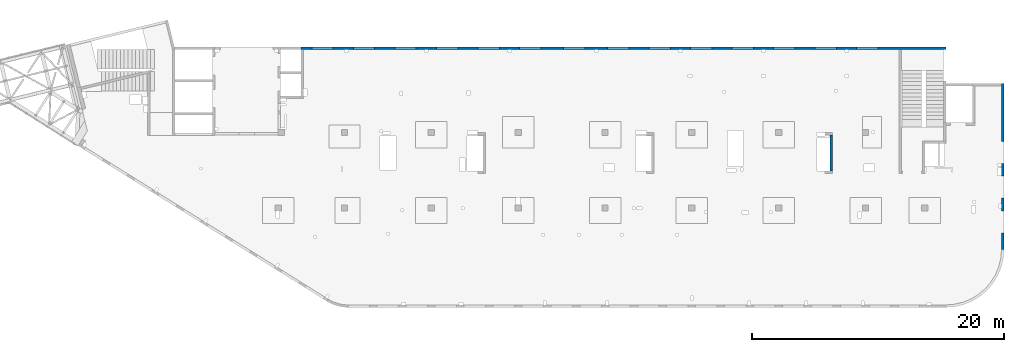
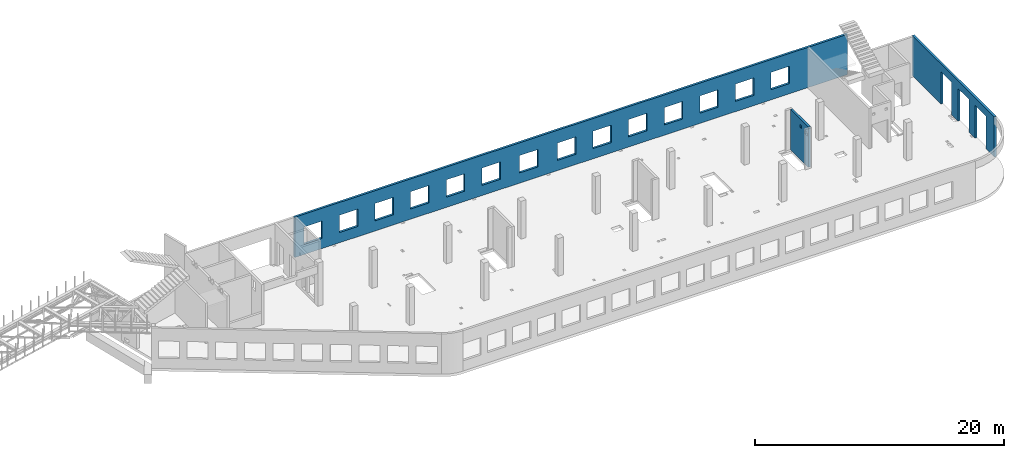
# One storey, part 67 of 67: 3 walls, 19 openings.
"""IFC4 building model written with IfcOpenShell, lengths in millimetres."""

from ifc_helpers import new_model, entity, si_unit, converted_unit, derived_unit, direction, frame, origin, place, context, subcontext, project, spatial, indexed_curve, outline, extrude, polygons, material, type_object, element, save


model = new_model("IFC4")

# Units and contexts
model_context = context("Model", 3, precision=0.01, world=origin(), true_north=direction((6.12303176911189e-17, 1.0)))
plan_context = context("Plan", 3, precision=0.01, world=origin(), true_north=direction((6.12303176911189e-17, 1.0)))
body_context = subcontext(model_context, "Body", "Model", "MODEL_VIEW")
ifc_project = project(units=[si_unit("LENGTHUNIT", "METRE", prefix="MILLI"), si_unit("AREAUNIT", "SQUARE_METRE"), si_unit("VOLUMEUNIT", "CUBIC_METRE"), converted_unit("PLANEANGLEUNIT", "DEGREE", entity("IfcRatioMeasure", 0.0174532925199433), si_unit("PLANEANGLEUNIT", "RADIAN"), dimensions=[0, 0, 0, 0, 0, 0, 0]), si_unit("MASSUNIT", "GRAM", prefix="KILO"), derived_unit("MASSDENSITYUNIT", [(si_unit("MASSUNIT", "GRAM", prefix="KILO"), 1), (si_unit("LENGTHUNIT", "METRE"), -3)]), derived_unit("MOMENTOFINERTIAUNIT", [(si_unit("LENGTHUNIT", "METRE"), 4)]), si_unit("TIMEUNIT", "SECOND"), si_unit("FREQUENCYUNIT", "HERTZ"), si_unit("THERMODYNAMICTEMPERATUREUNIT", "DEGREE_CELSIUS"), derived_unit("THERMALTRANSMITTANCEUNIT", [(si_unit("MASSUNIT", "GRAM", prefix="KILO"), 1), (si_unit("THERMODYNAMICTEMPERATUREUNIT", "KELVIN"), -1), (si_unit("TIMEUNIT", "SECOND"), -3)]), derived_unit("VOLUMETRICFLOWRATEUNIT", [(si_unit("LENGTHUNIT", "METRE"), 3), (si_unit("TIMEUNIT", "SECOND"), -1)]), derived_unit("MASSFLOWRATEUNIT", [(si_unit("MASSUNIT", "GRAM", prefix="KILO"), 1), (si_unit("TIMEUNIT", "SECOND"), -1)]), derived_unit("ROTATIONALFREQUENCYUNIT", [(si_unit("TIMEUNIT", "SECOND"), -1)]), si_unit("ELECTRICCURRENTUNIT", "AMPERE"), si_unit("ELECTRICVOLTAGEUNIT", "VOLT"), si_unit("POWERUNIT", "WATT"), si_unit("FORCEUNIT", "NEWTON", prefix="KILO"), si_unit("ILLUMINANCEUNIT", "LUX"), si_unit("LUMINOUSFLUXUNIT", "LUMEN"), si_unit("LUMINOUSINTENSITYUNIT", "CANDELA"), derived_unit("USERDEFINED", [(si_unit("MASSUNIT", "GRAM", prefix="KILO"), -1), (si_unit("LENGTHUNIT", "METRE"), -2), (si_unit("TIMEUNIT", "SECOND"), 3), (si_unit("LUMINOUSFLUXUNIT", "LUMEN"), 1)]), derived_unit("LINEARVELOCITYUNIT", [(si_unit("LENGTHUNIT", "METRE"), 1), (si_unit("TIMEUNIT", "SECOND"), -1)]), si_unit("PRESSUREUNIT", "PASCAL"), derived_unit("USERDEFINED", [(si_unit("LENGTHUNIT", "METRE"), -2), (si_unit("MASSUNIT", "GRAM", prefix="KILO"), 1), (si_unit("TIMEUNIT", "SECOND"), -2)]), derived_unit("LINEARFORCEUNIT", [(si_unit("MASSUNIT", "GRAM", prefix="KILO"), 1), (si_unit("LENGTHUNIT", "METRE"), 1), (si_unit("TIMEUNIT", "SECOND"), -2), (si_unit("LENGTHUNIT", "METRE"), -1)]), derived_unit("PLANARFORCEUNIT", [(si_unit("MASSUNIT", "GRAM", prefix="KILO"), 1), (si_unit("LENGTHUNIT", "METRE"), 1), (si_unit("TIMEUNIT", "SECOND"), -2), (si_unit("LENGTHUNIT", "METRE"), -2)])], contexts=[model_context, plan_context])

# Site, building, storey
site_placement = place(None, origin())
site = spatial("IfcSite", under=ifc_project, at=site_placement, CompositionType="ELEMENT")
building_placement = place(site_placement, origin())
building = spatial("IfcBuilding", under=site, at=building_placement, CompositionType="ELEMENT")
storey_placement = place(building_placement, frame((0.0, 0.0, 19800.0)))
storey = spatial("IfcBuildingStorey", under=building, at=storey_placement, CompositionType="ELEMENT", Elevation=19800.0)

# Wall, openings
ifc_material = material()
wall_type = type_object("IfcWallType", PredefinedType="STANDARD")
wall_1_placement = place(storey_placement, frame((68970.0002685547, 20399.9998657227, -150.0), z_axis=(0.0, 0.0, 1.0), x_axis=(-1.0, 0.0, 0.0)))
wall_1 = element("IfcWall", 1, at=wall_1_placement, inside=storey, type_object=wall_type, material=ifc_material, PredefinedType="NOTDEFINED", context=body_context, shape_type="Tessellation", body=[
    polygons([(48700.0, -100.000000000319, 2700.0), (50400.0, -100.000000000319, 2700.0), (50400.0, -100.000000000319, 1000.00000000001), (48700.0, -100.000000000319, 1000.00000000001), (45400.0, -100.000000000319, 2700.0), (47100.0, -100.000000000319, 2700.0), (47100.0, -100.000000000319, 1000.00000000001), (45400.0, -100.000000000319, 1000.00000000001), (42100.0, -100.000000000315, 2700.0), (43800.0, -100.000000000319, 2700.0), (43800.0, -100.000000000319, 1000.00000000001), (42100.0, -100.000000000315, 1000.00000000001), (38800.0, -100.000000000315, 2700.0), (40500.0, -100.000000000315, 2700.0), (40500.0, -100.000000000315, 1000.00000000001), (38800.0, -100.000000000315, 1000.00000000001), (35500.0, -100.000000000315, 2700.0), (37200.0, -100.000000000315, 2700.0), (37200.0, -100.000000000315, 1000.00000000001), (35500.0, -100.000000000315, 1000.00000000001), (28700.0, -100.000000000315, 2700.0), (30400.0, -100.000000000315, 2700.0), (30400.0, -100.000000000315, 1000.00000000001), (28700.0, -100.000000000315, 1000.00000000001), (25200.0, -100.000000000319, 2700.0), (26900.0, -100.000000000315, 2700.0), (26900.0, -100.000000000315, 1000.00000000001), (25200.0, -100.000000000319, 1000.00000000001), (21900.0, -100.000000000319, 2700.0), (23600.0, -100.000000000319, 2700.0), (23600.0, -100.000000000319, 1000.00000000001), (21900.0, -100.000000000319, 1000.00000000001), (18600.0, -100.000000000319, 2700.0), (20300.0, -100.000000000319, 2700.0), (20300.0, -100.000000000319, 1000.00000000001), (18600.0, -100.000000000319, 1000.00000000001), (15300.0, -100.000000000319, 2700.0), (17000.0, -100.000000000319, 2700.0), (17000.0, -100.000000000319, 1000.00000000001), (15300.0, -100.000000000319, 1000.00000000001), (12000.0, -100.000000000319, 2700.0), (13700.0, -100.000000000319, 2700.0), (13700.0, -100.000000000319, 1000.00000000001), (12000.0, -100.000000000319, 1000.00000000001), (8700.00000000004, -100.000000000319, 2700.0), (10400.0, -100.000000000319, 2700.0), (10400.0, -100.000000000319, 1000.00000000001), (8700.00000000004, -100.000000000319, 1000.00000000001), (5400.00000000004, -100.000000000319, 2700.0), (7100.00000000004, -100.000000000319, 2700.0), (7100.00000000004, -100.000000000319, 1000.00000000001), (5400.00000000004, -100.000000000319, 1000.00000000001), (32200.0, -100.000000000315, 2700.0), (33900.0, -100.000000000315, 2700.0), (33900.0, -100.000000000315, 1000.00000000001), (32200.0, -100.000000000315, 1000.00000000001), (-1.0404017477463e-11, -99.9999999999989, 0.0), (3539.99999999995, -99.9999999999989, 0.0), (51245.0, -99.9999999999989, 0.0), (51245.0, -99.9999999999989, 3950.0), (3539.99999999995, -99.9999999999989, 3950.0), (-1.0404017477463e-11, -99.9999999999989, 3950.0), (-1.03870313266876e-11, 99.9999999999989, 0.0), (-1.03870313266876e-11, 99.9999999999989, 3950.0), (3539.99999999996, 99.9999999999989, 3950.0), (3739.99999999996, 99.9999999999989, 3950.0), (51045.0, 99.9999999999989, 3950.0), (51245.0, 99.9999999999989, 3950.0), (51245.0, 99.9999999999989, 0.0), (51045.0, 99.9999999999989, 0.0), (3739.99999999996, 99.9999999999989, 0.0), (3539.99999999996, 99.9999999999989, 0.0), (50400.0, 99.9999999999989, 2700.0), (48700.0, 99.9999999999989, 2700.0), (48700.0, 99.9999999999989, 1000.00000000001), (50400.0, 99.9999999999989, 1000.00000000001), (47100.0, 99.9999999999989, 2700.0), (45400.0, 99.9999999999989, 2700.0), (45400.0, 99.9999999999989, 1000.00000000001), (47100.0, 99.9999999999989, 1000.00000000001), (43800.0, 99.9999999999989, 2700.0), (42100.0, 100.000000000003, 2700.0), (42100.0, 100.000000000003, 1000.00000000001), (43800.0, 99.9999999999989, 1000.00000000001), (40500.0, 100.000000000003, 2700.0), (38800.0, 100.000000000003, 2700.0), (38800.0, 100.000000000003, 1000.00000000001), (40500.0, 100.000000000003, 1000.00000000001), (37200.0, 100.000000000003, 2700.0), (35500.0, 100.000000000003, 2700.0), (35500.0, 100.000000000003, 1000.00000000001), (37200.0, 100.000000000003, 1000.00000000001), (30400.0, 100.000000000003, 2700.0), (28700.0, 100.000000000003, 2700.0), (28700.0, 100.000000000003, 1000.00000000001), (30400.0, 100.000000000003, 1000.00000000001), (26900.0, 100.000000000003, 2700.0), (25200.0, 99.9999999999989, 2700.0), (25200.0, 99.9999999999989, 1000.00000000001), (26900.0, 100.000000000003, 1000.00000000001), (23600.0, 99.9999999999989, 2700.0), (21900.0, 99.9999999999989, 2700.0), (21900.0, 99.9999999999989, 1000.00000000001), (23600.0, 99.9999999999989, 1000.00000000001), (20300.0, 99.9999999999989, 2700.0), (18600.0, 99.9999999999989, 2700.0), (18600.0, 99.9999999999989, 1000.00000000001), (20300.0, 99.9999999999989, 1000.00000000001), (17000.0, 99.9999999999989, 2700.0), (15300.0, 99.9999999999989, 2700.0), (15300.0, 99.9999999999989, 1000.00000000001), (17000.0, 99.9999999999989, 1000.00000000001), (13700.0, 99.9999999999989, 2700.0), (12000.0, 99.9999999999989, 2700.0), (12000.0, 99.9999999999989, 1000.00000000001), (13700.0, 99.9999999999989, 1000.00000000001), (10400.0, 99.9999999999989, 2700.0), (8700.00000000004, 99.9999999999989, 2700.0), (8700.00000000004, 99.9999999999989, 1000.00000000001), (10400.0, 99.9999999999989, 1000.00000000001), (7100.00000000004, 99.9999999999989, 2700.0), (5400.00000000004, 99.9999999999989, 2700.0), (5400.00000000004, 99.9999999999989, 1000.00000000001), (7100.00000000004, 99.9999999999989, 1000.00000000001), (33900.0, 100.000000000003, 2700.0), (32200.0, 100.000000000003, 2700.0), (32200.0, 100.000000000003, 1000.00000000001), (33900.0, 100.000000000003, 1000.00000000001)], [[[57, 58, 59, 60, 61, 62], [1, 2, 3, 4], [5, 6, 7, 8], [9, 10, 11, 12], [13, 14, 15, 16], [17, 18, 19, 20], [21, 22, 23, 24], [25, 26, 27, 28], [29, 30, 31, 32], [33, 34, 35, 36], [37, 38, 39, 40], [41, 42, 43, 44], [45, 46, 47, 48], [49, 50, 51, 52], [53, 54, 55, 56]], [[63, 64, 65, 66, 67, 68, 69, 70, 71, 72], [73, 74, 75, 76], [77, 78, 79, 80], [81, 82, 83, 84], [85, 86, 87, 88], [89, 90, 91, 92], [93, 94, 95, 96], [97, 98, 99, 100], [101, 102, 103, 104], [105, 106, 107, 108], [109, 110, 111, 112], [113, 114, 115, 116], [117, 118, 119, 120], [121, 122, 123, 124], [125, 126, 127, 128]], [[59, 58, 57, 63, 72, 71, 70, 69]], [[62, 61, 60, 68, 67, 66, 65, 64]], [[57, 62, 64, 63]], [[2, 1, 74, 73]], [[2, 73, 76, 3]], [[3, 76, 75, 4]], [[74, 1, 4, 75]], [[6, 5, 78, 77]], [[6, 77, 80, 7]], [[7, 80, 79, 8]], [[78, 5, 8, 79]], [[10, 9, 82, 81]], [[10, 81, 84, 11]], [[11, 84, 83, 12]], [[82, 9, 12, 83]], [[14, 13, 86, 85]], [[14, 85, 88, 15]], [[15, 88, 87, 16]], [[86, 13, 16, 87]], [[18, 17, 90, 89]], [[18, 89, 92, 19]], [[19, 92, 91, 20]], [[90, 17, 20, 91]], [[22, 21, 94, 93]], [[22, 93, 96, 23]], [[23, 96, 95, 24]], [[94, 21, 24, 95]], [[26, 25, 98, 97]], [[26, 97, 100, 27]], [[27, 100, 99, 28]], [[98, 25, 28, 99]], [[30, 29, 102, 101]], [[30, 101, 104, 31]], [[31, 104, 103, 32]], [[102, 29, 32, 103]], [[34, 33, 106, 105]], [[34, 105, 108, 35]], [[35, 108, 107, 36]], [[106, 33, 36, 107]], [[38, 37, 110, 109]], [[38, 109, 112, 39]], [[39, 112, 111, 40]], [[110, 37, 40, 111]], [[42, 41, 114, 113]], [[42, 113, 116, 43]], [[43, 116, 115, 44]], [[114, 41, 44, 115]], [[46, 45, 118, 117]], [[46, 117, 120, 47]], [[47, 120, 119, 48]], [[118, 45, 48, 119]], [[50, 49, 122, 121]], [[50, 121, 124, 51]], [[51, 124, 123, 52]], [[122, 49, 52, 123]], [[54, 53, 126, 125]], [[54, 125, 128, 55]], [[55, 128, 127, 56]], [[126, 53, 56, 127]], [[60, 59, 69, 68]]], closed=True),
])
opening_1_placement = place(wall_1_placement, frame((68970.0002685547, 20399.9998657227, 150.0), z_axis=(0.0, 0.0, 1.0), x_axis=(-1.0, 0.0, 0.0)))
element("IfcOpeningElement", 2, at=opening_1_placement, cuts=wall_1, PredefinedType="OPENING", context=body_context, shape_type="SweptSolid", body=[
    extrude(outline(indexed_curve([(-850.000000000002, -849.999999999993), (850.0, -849.999999999993), (850.0, 849.999999999993), (-850.000000000002, 849.999999999993), (-850.000000000002, -849.999999999993)], self_intersect=False)), frame((19420.0002685547, 20499.9998657236, 1700.0), z_axis=(0.0, -1.0, 0.0), x_axis=(-1.0, 0.0, 0.0)), (0.0, 0.0, 1.0), 200.000000000959),
])
opening_2_placement = place(wall_1_placement, frame((68970.0002685547, 20399.9998657227, 150.0), z_axis=(0.0, 0.0, 1.0), x_axis=(-1.0, 0.0, 0.0)))
element("IfcOpeningElement", 3, at=opening_2_placement, cuts=wall_1, PredefinedType="OPENING", context=body_context, shape_type="SweptSolid", body=[
    extrude(outline(indexed_curve([(-850.000000000002, -849.999999999993), (849.999999999997, -849.999999999993), (849.999999999997, 849.999999999993), (-850.000000000002, 849.999999999993), (-850.000000000002, -849.999999999993)], self_intersect=False)), frame((22720.0002685547, 20499.9998657236, 1700.0), z_axis=(0.0, -1.0, 0.0), x_axis=(-1.0, 0.0, 0.0)), (0.0, 0.0, 1.0), 200.000000000959),
])
opening_3_placement = place(wall_1_placement, frame((68970.0002685547, 20399.9998657227, 150.0), z_axis=(0.0, 0.0, 1.0), x_axis=(-1.0, 0.0, 0.0)))
element("IfcOpeningElement", 4, at=opening_3_placement, cuts=wall_1, PredefinedType="OPENING", context=body_context, shape_type="SweptSolid", body=[
    extrude(outline(indexed_curve([(-850.000000000002, -849.999999999993), (849.999999999997, -849.999999999993), (849.999999999997, 849.999999999993), (-850.000000000002, 849.999999999993), (-850.000000000002, -849.999999999993)], self_intersect=False)), frame((26020.0002685547, 20499.9998657236, 1700.0), z_axis=(0.0, -1.0, 0.0), x_axis=(-1.0, 0.0, 0.0)), (0.0, 0.0, 1.0), 200.000000000959),
])
opening_4_placement = place(wall_1_placement, frame((68970.0002685547, 20399.9998657227, 150.0), z_axis=(0.0, 0.0, 1.0), x_axis=(-1.0, 0.0, 0.0)))
element("IfcOpeningElement", 5, at=opening_4_placement, cuts=wall_1, PredefinedType="OPENING", context=body_context, shape_type="SweptSolid", body=[
    extrude(outline(indexed_curve([(-850.000000000002, -849.999999999993), (849.999999999997, -849.999999999993), (849.999999999997, 849.999999999993), (-850.000000000002, 849.999999999993), (-850.000000000002, -849.999999999993)], self_intersect=False)), frame((29320.0002685547, 20499.9998657236, 1700.0), z_axis=(0.0, -1.0, 0.0), x_axis=(-1.0, 0.0, 0.0)), (0.0, 0.0, 1.0), 200.000000000959),
])
opening_5_placement = place(wall_1_placement, frame((68970.0002685547, 20399.9998657227, 150.0), z_axis=(0.0, 0.0, 1.0), x_axis=(-1.0, 0.0, 0.0)))
element("IfcOpeningElement", 6, at=opening_5_placement, cuts=wall_1, PredefinedType="OPENING", context=body_context, shape_type="SweptSolid", body=[
    extrude(outline(indexed_curve([(-849.999999999997, -849.999999999993), (850.000000000002, -849.999999999993), (850.000000000002, 849.999999999993), (-849.999999999997, 849.999999999993), (-849.999999999997, -849.999999999993)], self_intersect=False)), frame((32620.0002685547, 20499.9998657236, 1700.0), z_axis=(0.0, -1.0, 0.0), x_axis=(-1.0, 0.0, 0.0)), (0.0, 0.0, 1.0), 200.000000000959),
])
opening_6_placement = place(wall_1_placement, frame((68970.0002685547, 20399.9998657227, 150.0), z_axis=(0.0, 0.0, 1.0), x_axis=(-1.0, 0.0, 0.0)))
element("IfcOpeningElement", 7, at=opening_6_placement, cuts=wall_1, PredefinedType="OPENING", context=body_context, shape_type="SweptSolid", body=[
    extrude(outline(indexed_curve([(-849.999999999997, -849.999999999993), (850.000000000006, -849.999999999993), (850.000000000006, 849.999999999993), (-849.999999999997, 849.999999999993), (-849.999999999997, -849.999999999993)], self_intersect=False)), frame((39420.0002685547, 20499.9998657236, 1700.0), z_axis=(0.0, -1.0, 0.0), x_axis=(-1.0, 0.0, 0.0)), (0.0, 0.0, 1.0), 200.000000000959),
])
opening_7_placement = place(wall_1_placement, frame((68970.0002685547, 20399.9998657227, 150.0), z_axis=(0.0, 0.0, 1.0), x_axis=(-1.0, 0.0, 0.0)))
element("IfcOpeningElement", 8, at=opening_7_placement, cuts=wall_1, PredefinedType="OPENING", context=body_context, shape_type="SweptSolid", body=[
    extrude(outline(indexed_curve([(-850.000000000006, -849.999999999993), (849.999999999997, -849.999999999993), (849.999999999997, 849.999999999993), (-850.000000000006, 849.999999999993), (-850.000000000006, -849.999999999993)], self_intersect=False)), frame((42920.0002685547, 20499.9998657236, 1700.0), z_axis=(0.0, -1.0, 0.0), x_axis=(-1.0, 0.0, 0.0)), (0.0, 0.0, 1.0), 200.000000000959),
])
opening_8_placement = place(wall_1_placement, frame((68970.0002685547, 20399.9998657227, 150.0), z_axis=(0.0, 0.0, 1.0), x_axis=(-1.0, 0.0, 0.0)))
element("IfcOpeningElement", 9, at=opening_8_placement, cuts=wall_1, PredefinedType="OPENING", context=body_context, shape_type="SweptSolid", body=[
    extrude(outline(indexed_curve([(-849.999999999997, -849.999999999993), (850.000000000006, -849.999999999993), (850.000000000006, 849.999999999993), (-849.999999999997, 849.999999999993), (-849.999999999997, -849.999999999993)], self_intersect=False)), frame((46220.0002685547, 20499.9998657236, 1700.0), z_axis=(0.0, -1.0, 0.0), x_axis=(-1.0, 0.0, 0.0)), (0.0, 0.0, 1.0), 200.000000000959),
])
opening_9_placement = place(wall_1_placement, frame((68970.0002685547, 20399.9998657227, 150.0), z_axis=(0.0, 0.0, 1.0), x_axis=(-1.0, 0.0, 0.0)))
element("IfcOpeningElement", 10, at=opening_9_placement, cuts=wall_1, PredefinedType="OPENING", context=body_context, shape_type="SweptSolid", body=[
    extrude(outline(indexed_curve([(-849.999999999997, -849.999999999993), (850.000000000006, -849.999999999993), (850.000000000006, 849.999999999993), (-849.999999999997, 849.999999999993), (-849.999999999997, -849.999999999993)], self_intersect=False)), frame((49520.0002685547, 20499.9998657236, 1700.0), z_axis=(0.0, -1.0, 0.0), x_axis=(-1.0, 0.0, 0.0)), (0.0, 0.0, 1.0), 200.000000000959),
])
opening_10_placement = place(wall_1_placement, frame((68970.0002685547, 20399.9998657227, 150.0), z_axis=(0.0, 0.0, 1.0), x_axis=(-1.0, 0.0, 0.0)))
element("IfcOpeningElement", 11, at=opening_10_placement, cuts=wall_1, PredefinedType="OPENING", context=body_context, shape_type="SweptSolid", body=[
    extrude(outline(indexed_curve([(-849.999999999997, -849.999999999993), (850.000000000006, -849.999999999993), (850.000000000006, 849.999999999993), (-849.999999999997, 849.999999999993), (-849.999999999997, -849.999999999993)], self_intersect=False)), frame((52820.0002685547, 20499.9998657236, 1700.0), z_axis=(0.0, -1.0, 0.0), x_axis=(-1.0, 0.0, 0.0)), (0.0, 0.0, 1.0), 200.000000000959),
])
opening_11_placement = place(wall_1_placement, frame((68970.0002685547, 20399.9998657227, 150.0), z_axis=(0.0, 0.0, 1.0), x_axis=(-1.0, 0.0, 0.0)))
element("IfcOpeningElement", 12, at=opening_11_placement, cuts=wall_1, PredefinedType="OPENING", context=body_context, shape_type="SweptSolid", body=[
    extrude(outline(indexed_curve([(-849.999999999997, -849.999999999993), (850.000000000006, -849.999999999993), (850.000000000006, 849.999999999993), (-849.999999999997, 849.999999999993), (-849.999999999997, -849.999999999993)], self_intersect=False)), frame((56120.0002685547, 20499.9998657236, 1700.0), z_axis=(0.0, -1.0, 0.0), x_axis=(-1.0, 0.0, 0.0)), (0.0, 0.0, 1.0), 200.000000000959),
])
opening_12_placement = place(wall_1_placement, frame((68970.0002685547, 20399.9998657227, 150.0), z_axis=(0.0, 0.0, 1.0), x_axis=(-1.0, 0.0, 0.0)))
element("IfcOpeningElement", 13, at=opening_12_placement, cuts=wall_1, PredefinedType="OPENING", context=body_context, shape_type="SweptSolid", body=[
    extrude(outline(indexed_curve([(-849.999999999997, -849.999999999993), (850.000000000006, -849.999999999993), (850.000000000006, 849.999999999993), (-849.999999999997, 849.999999999993), (-849.999999999997, -849.999999999993)], self_intersect=False)), frame((59420.0002685547, 20499.9998657236, 1700.0), z_axis=(0.0, -1.0, 0.0), x_axis=(-1.0, 0.0, 0.0)), (0.0, 0.0, 1.0), 200.000000000959),
])
opening_13_placement = place(wall_1_placement, frame((68970.0002685547, 20399.9998657227, 150.0), z_axis=(0.0, 0.0, 1.0), x_axis=(-1.0, 0.0, 0.0)))
element("IfcOpeningElement", 14, at=opening_13_placement, cuts=wall_1, PredefinedType="OPENING", context=body_context, shape_type="SweptSolid", body=[
    extrude(outline(indexed_curve([(-849.999999999997, -849.999999999993), (850.000000000006, -849.999999999993), (850.000000000006, 849.999999999993), (-849.999999999997, 849.999999999993), (-849.999999999997, -849.999999999993)], self_intersect=False)), frame((62720.0002685547, 20499.9998657236, 1700.0), z_axis=(0.0, -1.0, 0.0), x_axis=(-1.0, 0.0, 0.0)), (0.0, 0.0, 1.0), 200.000000000959),
])
opening_14_placement = place(wall_1_placement, frame((68970.0002685547, 20399.9998657227, 150.0), z_axis=(0.0, 0.0, 1.0), x_axis=(-1.0, 0.0, 0.0)))
element("IfcOpeningElement", 15, at=opening_14_placement, cuts=wall_1, PredefinedType="OPENING", context=body_context, shape_type="SweptSolid", body=[
    extrude(outline(indexed_curve([(-849.999999999997, -849.999999999993), (850.000000000002, -849.999999999993), (850.000000000002, 849.999999999993), (-849.999999999997, 849.999999999993), (-849.999999999997, -849.999999999993)], self_intersect=False)), frame((35920.0002685547, 20499.9998657236, 1700.0), z_axis=(0.0, -1.0, 0.0), x_axis=(-1.0, 0.0, 0.0)), (0.0, 0.0, 1.0), 200.000000000959),
])

wall_2_placement = place(storey_placement, frame((73469.9994506836, 4399.9992263554, -150.0), z_axis=(0.0, 0.0, 1.0), x_axis=(0.0, 1.0, 0.0)))
wall_2 = element("IfcWall", 16, at=wall_2_placement, inside=storey, type_object=wall_type, material=ifc_material, PredefinedType="NOTDEFINED", context=body_context, shape_type="Tessellation", body=[
    polygons([(13170.0, -99.9999999999926, 3950.0), (5.41433564649196e-13, -99.9999999999984, 3950.0), (5.41433564649196e-13, -99.9999999999984, 3200.0), (5.41433564649196e-13, -99.9999999999984, 0.0), (1325.0, -99.9999999999969, 0.0), (1325.0, -99.9999999999969, 3200.0), (3075.0, -99.999999999995, 3200.0), (3075.0, -99.999999999995, 0.0), (4075.0, -100.000000000003, 0.0), (4075.0, -100.000000000003, 3200.0), (5825.0, -100.000000000001, 3200.0), (5825.0, -100.000000000001, 0.0), (6825.0, -99.9999999999995, 0.0), (6825.0, -99.9999999999995, 3200.0), (8575.0, -99.9999999999976, 3200.0), (8575.0, -99.9999999999976, 0.0), (13170.0, -99.9999999999926, 0.0), (0.0, 99.9999999999994, 3950.0), (3410.00000000003, 100.000000000003, 3950.0), (3610.00000000003, 100.000000000003, 3950.0), (5885.00000000002, 99.9999999999973, 3950.0), (6485.00000000003, 99.9999999999979, 3950.0), (6650.00000000004, 99.9999999999981, 3950.0), (6850.00000000003, 99.9999999999983, 3950.0), (12970.0, 99.9999999999964, 3950.0), (13170.0, 99.9999999999966, 3950.0), (13170.0, 99.9999999999966, 0.0), (12970.0, 99.9999999999964, 0.0), (8575.0, 100.0, 0.0), (8575.0, 100.000000000321, 3200.0), (6825.0, 100.000000000319, 3200.0), (6825.0, 99.9999999999983, 0.0), (5825.0, 99.9999999999972, 0.0), (5825.0, 100.000000000318, 3200.0), (4075.0, 100.000000000316, 3200.0), (4075.0, 99.9999999999953, 0.0), (3600.00000000004, 100.000000000003, 0.0), (3300.00000000003, 100.000000000003, 0.0), (3075.0, 100.000000000003, 0.0), (3075.0, 100.000000000315, 3200.0), (1325.0, 100.000000000313, 3200.0), (1325.0, 100.000000000001, 0.0), (0.0, 99.9999999999994, 0.0), (0.0, 99.9999999999994, 3200.0)], [[[1, 2, 3, 4, 5, 6, 7, 8, 9, 10, 11, 12, 13, 14, 15, 16, 17]], [[18, 19, 20, 21, 22, 23, 24, 25, 26, 27, 28, 29, 30, 31, 32, 33, 34, 35, 36, 37, 38, 39, 40, 41, 42, 43, 44]], [[4, 43, 42, 5]], [[2, 1, 26, 25, 24, 23, 22, 21, 20, 19, 18]], [[4, 3, 2, 18, 44, 43]], [[1, 17, 27, 26]], [[14, 31, 30, 15]], [[31, 14, 13, 32]], [[15, 30, 29, 16]], [[10, 35, 34, 11]], [[35, 10, 9, 36]], [[11, 34, 33, 12]], [[6, 41, 40, 7]], [[41, 6, 5, 42]], [[7, 40, 39, 8]], [[36, 9, 8, 39, 38, 37]], [[32, 13, 12, 33]], [[27, 17, 16, 29, 28]]], closed=True),
])
opening_15_placement = place(wall_2_placement, frame((-4399.9992263554, 73469.9994506836, 150.0), z_axis=(0.0, 0.0, 1.0), x_axis=(0.0, -1.0, 0.0)))
element("IfcOpeningElement", 17, at=opening_15_placement, cuts=wall_2, PredefinedType="OPENING", context=body_context, shape_type="SweptSolid", body=[
    extrude(outline(indexed_curve([(-1600.0, -875.0), (1599.99999999999, -875.0), (1599.99999999999, 875.0), (-1600.0, 875.0), (-1600.0, -875.0)], self_intersect=False)), frame((73569.9994506836, 12099.9992263554, 1450.0), z_axis=(-1.0, 0.0, 0.0), x_axis=(0.0, 0.0, -1.0)), (0.0, 0.0, 1.0), 200.000000000968),
])
opening_16_placement = place(wall_2_placement, frame((-4399.9992263554, 73469.9994506836, 150.0), z_axis=(0.0, 0.0, 1.0), x_axis=(0.0, -1.0, 0.0)))
element("IfcOpeningElement", 18, at=opening_16_placement, cuts=wall_2, PredefinedType="OPENING", context=body_context, shape_type="SweptSolid", body=[
    extrude(outline(indexed_curve([(-1600.0, -875.0), (1599.99999999999, -875.0), (1599.99999999999, 874.999999999999), (-1600.0, 874.999999999999), (-1600.0, -875.0)], self_intersect=False)), frame((73569.9994506836, 9349.99922635541, 1450.0), z_axis=(-1.0, 0.0, 0.0), x_axis=(0.0, 0.0, -1.0)), (0.0, 0.0, 1.0), 200.000000000968),
])
opening_17_placement = place(wall_2_placement, frame((-4399.9992263554, 73469.9994506836, 150.0), z_axis=(0.0, 0.0, 1.0), x_axis=(0.0, -1.0, 0.0)))
element("IfcOpeningElement", 19, at=opening_17_placement, cuts=wall_2, PredefinedType="OPENING", context=body_context, shape_type="SweptSolid", body=[
    extrude(outline(indexed_curve([(-1600.0, -874.999999999999), (1599.99999999999, -874.999999999999), (1599.99999999999, 875.0), (-1600.0, 875.0), (-1600.0, -874.999999999999)], self_intersect=False)), frame((73569.9994506836, 6599.9992263554, 1450.0), z_axis=(-1.0, 0.0, 0.0), x_axis=(0.0, 0.0, -1.0)), (0.0, 0.0, 1.0), 200.000000000968),
])

wall_3_placement = place(storey_placement, frame((59830.0002685547, 13499.9992263555, -150.0), z_axis=(0.0, 0.0, 1.0), x_axis=(0.0, -1.0, 0.0)))
wall_3 = element("IfcWall", 20, at=wall_3_placement, inside=storey, type_object=wall_type, material=ifc_material, PredefinedType="NOTDEFINED", context=body_context, shape_type="Tessellation", body=[
    polygons([(0.0, -99.9999999999859, 0.0), (2875.00000000002, -99.9999999999859, 0.0), (2875.00000000002, -99.9999999999859, 3950.0), (0.0, -99.9999999999859, 3950.0), (2360.00000000002, -100.000000000003, 3330.0), (2710.00000000001, -100.000000000003, 3330.0), (2710.00000000001, -100.000000000003, 2980.00000000001), (2360.00000000002, -100.000000000003, 2980.00000000001), (1560.00000000002, -100.000000000003, 3400.0), (1810.00000000002, -100.000000000003, 3400.0), (1810.00000000002, -100.000000000003, 3150.00000000001), (1560.00000000002, -100.000000000003, 3150.00000000001), (2.16573425859679e-12, 100.000000000003, 0.0), (2.16573425859679e-12, 100.000000000003, 3950.0), (2875.00000000002, 100.000000000003, 3950.0), (2875.00000000002, 100.000000000003, 0.0), (2710.00000000002, 100.000000000324, 3330.0), (2360.00000000002, 100.000000000324, 3330.0), (2360.00000000002, 100.000000000324, 2980.00000000001), (2710.00000000002, 100.000000000324, 2980.00000000001), (1810.00000000002, 100.000000000324, 3400.0), (1560.00000000002, 100.000000000324, 3400.0), (1560.00000000002, 100.000000000324, 3150.00000000001), (1810.00000000002, 100.000000000324, 3150.00000000001)], [[[1, 2, 3, 4], [5, 6, 7, 8], [9, 10, 11, 12]], [[13, 14, 15, 16], [17, 18, 19, 20], [21, 22, 23, 24]], [[2, 1, 13, 16]], [[4, 3, 15, 14]], [[1, 4, 14, 13]], [[3, 2, 16, 15]], [[18, 17, 6, 5]], [[18, 5, 8, 19]], [[19, 8, 7, 20]], [[6, 17, 20, 7]], [[22, 21, 10, 9]], [[22, 9, 12, 23]], [[23, 12, 11, 24]], [[10, 21, 24, 11]]], closed=True),
])
opening_18_placement = place(wall_3_placement, frame((13499.9992263555, -59830.0002685547, 150.0), z_axis=(0.0, 0.0, 1.0), x_axis=(0.0, 1.0, 0.0)))
element("IfcOpeningElement", 21, at=opening_18_placement, cuts=wall_3, PredefinedType="OPENING", context=body_context, shape_type="SweptSolid", body=[
    extrude(outline(indexed_curve([(-174.999999999995, -174.999999999999), (174.999999999991, -174.999999999999), (174.999999999991, 175.000000000001), (-174.999999999995, 175.000000000001), (-174.999999999995, -174.999999999999)], self_intersect=False)), frame((59730.0002685547, 10964.9992263555, 3005.0), z_axis=(1.0, 0.0, 0.0), x_axis=(0.0, 0.0, -1.0)), (0.0, 0.0, 1.0), 200.000000000968),
])
opening_19_placement = place(wall_3_placement, frame((13499.9992263555, -59830.0002685547, 150.0), z_axis=(0.0, 0.0, 1.0), x_axis=(0.0, 1.0, 0.0)))
element("IfcOpeningElement", 22, at=opening_19_placement, cuts=wall_3, PredefinedType="OPENING", context=body_context, shape_type="SweptSolid", body=[
    extrude(outline(indexed_curve([(-124.999999999993, -125.0), (124.999999999993, -125.0), (124.999999999993, 125.0), (-124.999999999993, 125.0), (-124.999999999993, -125.0)], self_intersect=False)), frame((59730.0002685547, 11814.9992263555, 3125.0), z_axis=(1.0, 0.0, 0.0), x_axis=(0.0, 0.0, -1.0)), (0.0, 0.0, 1.0), 200.000000000968),
])

save(model, "model.ifc")
